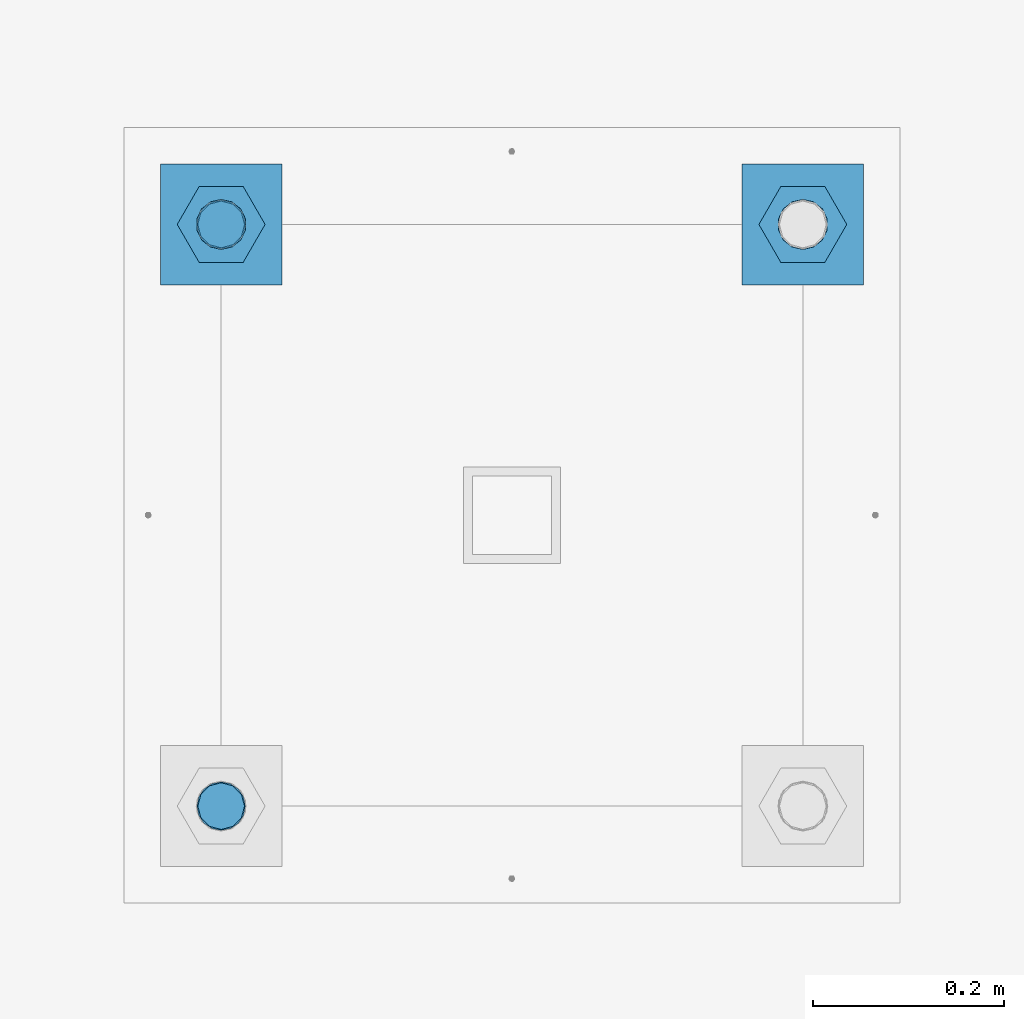
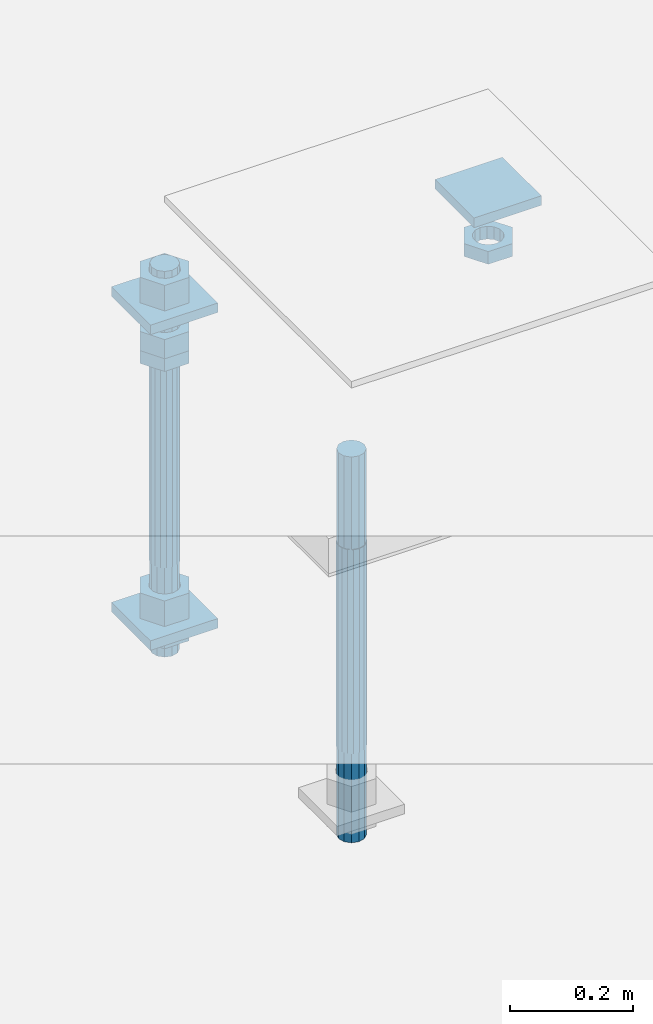
# One storey, part 2749 of 3843: 11 beams, 1 element without a shape of its own.
"""IFC2X3 building model written with IfcOpenShell, lengths in millimetres."""

from ifc_helpers import new_model, si_unit, frame, origin_with_axes, place, context, subcontext, project, spatial, faceted_brep, material, type_object, element, aggregate, save


model = new_model("IFC2X3")

# Units and contexts
model_context = context("Model", 3, precision=1e-05, world=origin_with_axes())
body_context = subcontext(model_context, "Body", "Model", "MODEL_VIEW")
ifc_project = project(units=[si_unit("LENGTHUNIT", "METRE", prefix="MILLI"), si_unit("AREAUNIT", "SQUARE_METRE"), si_unit("VOLUMEUNIT", "CUBIC_METRE"), si_unit("MASSUNIT", "GRAM", prefix="KILO"), si_unit("TIMEUNIT", "SECOND"), si_unit("PLANEANGLEUNIT", "RADIAN"), si_unit("SOLIDANGLEUNIT", "STERADIAN"), si_unit("THERMODYNAMICTEMPERATUREUNIT", "DEGREE_CELSIUS"), si_unit("LUMINOUSINTENSITYUNIT", "LUMEN")], contexts=[model_context])

# Site, building, storey
site_placement = place(None, origin_with_axes())
site = spatial("IfcSite", under=ifc_project, at=site_placement, CompositionType="ELEMENT")
building_placement = place(site_placement, origin_with_axes())
building = spatial("IfcBuilding", under=site, at=building_placement, Name="Undefined", CompositionType="ELEMENT")
storey_placement = place(building_placement, origin_with_axes())
storey = spatial("IfcBuildingStorey", under=building, at=storey_placement, Name="Undefined", CompositionType="ELEMENT", Elevation=0.0)

# Assembly, beams
assembly_placement = place(storey_placement, origin_with_axes())
assembly = element("IfcElementAssembly", 1, at=assembly_placement, inside=storey, Name="TEMPLATE", AssemblyPlace="NOTDEFINED", PredefinedType="RIGID_FRAME")
ifc_material_1 = material(Name="STEEL/A36")
beam_type_1 = type_object("IfcBeamType", PredefinedType="NOTDEFINED")
beam_1_placement = place(assembly_placement, frame((111734.6, 45808.9000015259, 29873.575), z_axis=(1.0, 0.0, 0.0), x_axis=(0.0, 1.0, 0.0)))
beam_1 = element("IfcBeam", 2, at=beam_1_placement, type_object=beam_type_1, material=ifc_material_1, Name="WASHER_PLATE", context=body_context, shape_type="Brep", body=[
    faceted_brep([(0.0, 9.52500000000146, -63.5), (0.0, 9.52500000000146, 63.5), (127.0, 9.52500000000146, 63.5), (127.0, 9.52500000000146, -63.5), (0.0, -9.52500000000146, 63.5), (127.0, -9.52500000000146, 63.5), (0.0, -9.52500000000146, -63.5), (127.0, -9.52500000000146, -63.5)], [[[0, 1, 2, 3]], [[1, 4, 5, 2]], [[4, 6, 7, 5]], [[6, 0, 3, 7]], [[5, 7, 3, 2]], [[6, 4, 1, 0]]]),
])
beam_2_placement = place(assembly_placement, frame((112344.2, 45808.9000015259, 29873.575), z_axis=(1.0, 0.0, 0.0), x_axis=(0.0, 1.0, 0.0)))
beam_2 = element("IfcBeam", 3, at=beam_2_placement, type_object=beam_type_1, material=ifc_material_1, Name="WASHER_PLATE", context=body_context, shape_type="Brep", body=[
    faceted_brep([(0.0, 9.52500000000146, -63.5), (0.0, 9.52500000000146, 63.5), (127.0, 9.52500000000146, 63.5), (127.0, 9.52500000000146, -63.5), (0.0, -9.52500000000146, 63.5), (127.0, -9.52500000000146, 63.5), (0.0, -9.52500000000146, -63.5), (127.0, -9.52500000000146, -63.5)], [[[0, 1, 2, 3]], [[1, 4, 5, 2]], [[4, 6, 7, 5]], [[6, 0, 3, 7]], [[5, 7, 3, 2]], [[6, 4, 1, 0]]]),
])
beam_3_placement = place(assembly_placement, frame((111734.6, 45808.9000015259, 29244.925), z_axis=(1.0, 0.0, 0.0), x_axis=(0.0, 1.0, 0.0)))
beam_3 = element("IfcBeam", 4, at=beam_3_placement, type_object=beam_type_1, material=ifc_material_1, Name="WASHER_PLATE", context=body_context, shape_type="Brep", body=[
    faceted_brep([(0.0, 9.52500000000146, -63.5), (0.0, 9.52500000000146, 63.5), (127.0, 9.52500000000146, 63.5), (127.0, 9.52500000000146, -63.5), (0.0, -9.52500000000146, 63.5), (127.0, -9.52500000000146, 63.5), (0.0, -9.52500000000146, -63.5), (127.0, -9.52500000000146, -63.5)], [[[0, 1, 2, 3]], [[1, 4, 5, 2]], [[4, 6, 7, 5]], [[6, 0, 3, 7]], [[5, 7, 3, 2]], [[6, 4, 1, 0]]]),
])
beam_type_2 = type_object("IfcBeamType", Name="2_HALF_NUT", PredefinedType="NOTDEFINED")
beam_4_placement = place(assembly_placement, frame((111734.6, 45872.4000015259, 29787.85), z_axis=(0.0, 1.0, 0.0), x_axis=(0.0, 0.0, -1.0)))
beam_4 = element("IfcBeam", 5, at=beam_4_placement, type_object=beam_type_2, material=ifc_material_1, Name="NUT", ObjectType="2_HALF_NUT", context=body_context, shape_type="Brep", body=[
    faceted_brep([(0.0, -46.0369987487793, 0.0), (0.0, -23.0184993743896, -39.869213104248), (25.4000000000015, -23.0184993743896, -39.869213104248), (25.4000000000015, -46.0369987487793, 0.0), (0.0, 23.0184993743896, -39.869213104248), (25.4000000000015, 23.0184993743896, -39.869213104248), (0.0, 46.0369987487793, 0.0), (25.4000000000015, 46.0369987487793, 0.0), (0.0, 23.0184993743896, 39.869213104248), (25.4000000000015, 23.0184993743896, 39.869213104248), (0.0, -23.0184993743896, 39.869213104248), (25.4000000000015, -23.0184993743896, 39.869213104248), (0.0, 0.0, 26.1940002441406), (0.0, 11.3650617044477, 23.5999013092805), (25.4000000000015, 11.3650617044477, 23.5999013092805), (25.4000000000015, 0.0, 26.1940002441406), (0.0, 20.4791109456419, 16.3316083006721), (25.4000000000015, 20.4791109456419, 16.3316083006721), (0.0, 25.5370200498292, 5.82867859874386), (25.4000000000015, 25.5370200498292, 5.82867859874386), (0.0, 25.5370200498292, -5.82867859874386), (25.4000000000015, 25.5370200498292, -5.82867859874386), (0.0, 20.4791109456419, -16.3316083006721), (25.4000000000015, 20.4791109456419, -16.3316083006721), (0.0, 11.3650617044477, -23.5999013092805), (25.4000000000015, 11.3650617044477, -23.5999013092805), (0.0, 0.0, -26.1940002441406), (25.4000000000015, 0.0, -26.1940002441406), (0.0, -11.3650617044477, -23.5999013092805), (25.4000000000015, -11.3650617044477, -23.5999013092805), (0.0, -20.4791109456419, -16.3316083006721), (25.4000000000015, -20.4791109456419, -16.3316083006721), (0.0, -25.5370200498292, -5.82867859874386), (25.4000000000015, -25.5370200498292, -5.82867859874386), (0.0, -25.5370200498292, 5.82867859874386), (25.4000000000015, -25.5370200498292, 5.82867859874386), (0.0, -20.4791109456419, 16.3316083006721), (25.4000000000015, -20.4791109456419, 16.3316083006721), (0.0, -11.3650617044477, 23.5999013092805), (25.4000000000015, -11.3650617044477, 23.5999013092805)], [[[0, 1, 2, 3]], [[1, 4, 5, 2]], [[4, 6, 7, 5]], [[6, 8, 9, 7]], [[8, 10, 11, 9]], [[10, 0, 3, 11]], [[12, 13, 14, 15]], [[13, 16, 17, 14]], [[16, 18, 19, 17]], [[18, 20, 21, 19]], [[20, 22, 23, 21]], [[22, 24, 25, 23]], [[24, 26, 27, 25]], [[26, 28, 29, 27]], [[28, 30, 31, 29]], [[30, 32, 33, 31]], [[32, 34, 35, 33]], [[34, 36, 37, 35]], [[36, 38, 39, 37]], [[38, 12, 15, 39]], [[5, 7, 9, 11, 3, 2], [17, 19, 21, 23, 25, 27, 29, 31, 33, 35, 37, 39, 15, 14]], [[10, 8, 6, 4, 1, 0], [38, 36, 34, 32, 30, 28, 26, 24, 22, 20, 18, 16, 13, 12]]]),
])
beam_5_placement = place(assembly_placement, frame((112344.2, 45872.4000015259, 29787.85), z_axis=(0.0, 1.0, 0.0), x_axis=(0.0, 0.0, -1.0)))
beam_5 = element("IfcBeam", 6, at=beam_5_placement, type_object=beam_type_2, material=ifc_material_1, Name="NUT", ObjectType="2_HALF_NUT", context=body_context, shape_type="Brep", body=[
    faceted_brep([(0.0, -46.0369987487793, 0.0), (0.0, -23.0184993743896, -39.869213104248), (25.4000000000015, -23.0184993743896, -39.869213104248), (25.4000000000015, -46.0369987487793, 0.0), (0.0, 23.0184993743896, -39.869213104248), (25.4000000000015, 23.0184993743896, -39.869213104248), (0.0, 46.0369987487793, 0.0), (25.4000000000015, 46.0369987487793, 0.0), (0.0, 23.0184993743896, 39.869213104248), (25.4000000000015, 23.0184993743896, 39.869213104248), (0.0, -23.0184993743896, 39.869213104248), (25.4000000000015, -23.0184993743896, 39.869213104248), (0.0, 0.0, 26.1940002441406), (0.0, 11.3650617044477, 23.5999013092805), (25.4000000000015, 11.3650617044477, 23.5999013092805), (25.4000000000015, 0.0, 26.1940002441406), (0.0, 20.4791109456419, 16.3316083006721), (25.4000000000015, 20.4791109456419, 16.3316083006721), (0.0, 25.5370200498292, 5.82867859874386), (25.4000000000015, 25.5370200498292, 5.82867859874386), (0.0, 25.5370200498292, -5.82867859874386), (25.4000000000015, 25.5370200498292, -5.82867859874386), (0.0, 20.4791109456419, -16.3316083006721), (25.4000000000015, 20.4791109456419, -16.3316083006721), (0.0, 11.3650617044477, -23.5999013092805), (25.4000000000015, 11.3650617044477, -23.5999013092805), (0.0, 0.0, -26.1940002441406), (25.4000000000015, 0.0, -26.1940002441406), (0.0, -11.3650617044477, -23.5999013092805), (25.4000000000015, -11.3650617044477, -23.5999013092805), (0.0, -20.4791109456419, -16.3316083006721), (25.4000000000015, -20.4791109456419, -16.3316083006721), (0.0, -25.5370200498292, -5.82867859874386), (25.4000000000015, -25.5370200498292, -5.82867859874386), (0.0, -25.5370200498292, 5.82867859874386), (25.4000000000015, -25.5370200498292, 5.82867859874386), (0.0, -20.4791109456419, 16.3316083006721), (25.4000000000015, -20.4791109456419, 16.3316083006721), (0.0, -11.3650617044477, 23.5999013092805), (25.4000000000015, -11.3650617044477, 23.5999013092805)], [[[0, 1, 2, 3]], [[1, 4, 5, 2]], [[4, 6, 7, 5]], [[6, 8, 9, 7]], [[8, 10, 11, 9]], [[10, 0, 3, 11]], [[12, 13, 14, 15]], [[13, 16, 17, 14]], [[16, 18, 19, 17]], [[18, 20, 21, 19]], [[20, 22, 23, 21]], [[22, 24, 25, 23]], [[24, 26, 27, 25]], [[26, 28, 29, 27]], [[28, 30, 31, 29]], [[30, 32, 33, 31]], [[32, 34, 35, 33]], [[34, 36, 37, 35]], [[36, 38, 39, 37]], [[38, 12, 15, 39]], [[5, 7, 9, 11, 3, 2], [17, 19, 21, 23, 25, 27, 29, 31, 33, 35, 37, 39, 15, 14]], [[10, 8, 6, 4, 1, 0], [38, 36, 34, 32, 30, 28, 26, 24, 22, 20, 18, 16, 13, 12]]]),
])
beam_6_placement = place(assembly_placement, frame((111734.6, 45872.4000015259, 29235.4), z_axis=(0.0, 1.0, 0.0), x_axis=(0.0, 0.0, -1.0)))
beam_6 = element("IfcBeam", 7, at=beam_6_placement, type_object=beam_type_2, material=ifc_material_1, Name="NUT", ObjectType="2_HALF_NUT", context=body_context, shape_type="Brep", body=[
    faceted_brep([(0.0, -46.0369987487793, 0.0), (0.0, -23.0184993743896, -39.869213104248), (25.4000000000015, -23.0184993743896, -39.869213104248), (25.4000000000015, -46.0369987487793, 0.0), (0.0, 23.0184993743896, -39.869213104248), (25.4000000000015, 23.0184993743896, -39.869213104248), (0.0, 46.0369987487793, 0.0), (25.4000000000015, 46.0369987487793, 0.0), (0.0, 23.0184993743896, 39.869213104248), (25.4000000000015, 23.0184993743896, 39.869213104248), (0.0, -23.0184993743896, 39.869213104248), (25.4000000000015, -23.0184993743896, 39.869213104248), (0.0, 0.0, 26.1940002441406), (0.0, 11.3650617044477, 23.5999013092805), (25.4000000000015, 11.3650617044477, 23.5999013092805), (25.4000000000015, 0.0, 26.1940002441406), (0.0, 20.4791109456419, 16.3316083006721), (25.4000000000015, 20.4791109456419, 16.3316083006721), (0.0, 25.5370200498292, 5.82867859874386), (25.4000000000015, 25.5370200498292, 5.82867859874386), (0.0, 25.5370200498292, -5.82867859874386), (25.4000000000015, 25.5370200498292, -5.82867859874386), (0.0, 20.4791109456419, -16.3316083006721), (25.4000000000015, 20.4791109456419, -16.3316083006721), (0.0, 11.3650617044477, -23.5999013092805), (25.4000000000015, 11.3650617044477, -23.5999013092805), (0.0, 0.0, -26.1940002441406), (25.4000000000015, 0.0, -26.1940002441406), (0.0, -11.3650617044477, -23.5999013092805), (25.4000000000015, -11.3650617044477, -23.5999013092805), (0.0, -20.4791109456419, -16.3316083006721), (25.4000000000015, -20.4791109456419, -16.3316083006721), (0.0, -25.5370200498292, -5.82867859874386), (25.4000000000015, -25.5370200498292, -5.82867859874386), (0.0, -25.5370200498292, 5.82867859874386), (25.4000000000015, -25.5370200498292, 5.82867859874386), (0.0, -20.4791109456419, 16.3316083006721), (25.4000000000015, -20.4791109456419, 16.3316083006721), (0.0, -11.3650617044477, 23.5999013092805), (25.4000000000015, -11.3650617044477, 23.5999013092805)], [[[0, 1, 2, 3]], [[1, 4, 5, 2]], [[4, 6, 7, 5]], [[6, 8, 9, 7]], [[8, 10, 11, 9]], [[10, 0, 3, 11]], [[12, 13, 14, 15]], [[13, 16, 17, 14]], [[16, 18, 19, 17]], [[18, 20, 21, 19]], [[20, 22, 23, 21]], [[22, 24, 25, 23]], [[24, 26, 27, 25]], [[26, 28, 29, 27]], [[28, 30, 31, 29]], [[30, 32, 33, 31]], [[32, 34, 35, 33]], [[34, 36, 37, 35]], [[36, 38, 39, 37]], [[38, 12, 15, 39]], [[5, 7, 9, 11, 3, 2], [17, 19, 21, 23, 25, 27, 29, 31, 33, 35, 37, 39, 15, 14]], [[10, 8, 6, 4, 1, 0], [38, 36, 34, 32, 30, 28, 26, 24, 22, 20, 18, 16, 13, 12]]]),
])
beam_type_3 = type_object("IfcBeamType", Name="2_HEAVY_HEX_NUT", PredefinedType="NOTDEFINED")
beam_7_placement = place(assembly_placement, frame((111734.6, 45872.4000015259, 29825.95), z_axis=(0.0, 1.0, 0.0), x_axis=(0.0, 0.0, -1.0)))
beam_7 = element("IfcBeam", 8, at=beam_7_placement, type_object=beam_type_3, material=ifc_material_1, Name="NUT", ObjectType="2_HEAVY_HEX_NUT", context=body_context, shape_type="Brep", body=[
    faceted_brep([(0.0, -46.0369987487793, 0.0), (0.0, -23.0184993743896, -39.869213104248), (38.0999999999985, -23.0184993743896, -39.869213104248), (38.0999999999985, -46.0369987487793, 0.0), (0.0, 23.0184993743896, -39.869213104248), (38.0999999999985, 23.0184993743896, -39.869213104248), (0.0, 46.0369987487793, 0.0), (38.0999999999985, 46.0369987487793, 0.0), (0.0, 23.0184993743896, 39.869213104248), (38.0999999999985, 23.0184993743896, 39.869213104248), (0.0, -23.0184993743896, 39.869213104248), (38.0999999999985, -23.0184993743896, 39.869213104248), (0.0, 0.0, 26.1940002441406), (0.0, 11.3650617044477, 23.5999013092805), (38.0999999999985, 11.3650617044477, 23.5999013092805), (38.0999999999985, 0.0, 26.1940002441406), (0.0, 20.4791109456419, 16.3316083006721), (38.0999999999985, 20.4791109456419, 16.3316083006721), (0.0, 25.5370200498292, 5.82867859874386), (38.0999999999985, 25.5370200498292, 5.82867859874386), (0.0, 25.5370200498292, -5.82867859874386), (38.0999999999985, 25.5370200498292, -5.82867859874386), (0.0, 20.4791109456419, -16.3316083006721), (38.0999999999985, 20.4791109456419, -16.3316083006721), (0.0, 11.3650617044477, -23.5999013092805), (38.0999999999985, 11.3650617044477, -23.5999013092805), (0.0, 0.0, -26.1940002441406), (38.0999999999985, 0.0, -26.1940002441406), (0.0, -11.3650617044477, -23.5999013092805), (38.0999999999985, -11.3650617044477, -23.5999013092805), (0.0, -20.4791109456419, -16.3316083006721), (38.0999999999985, -20.4791109456419, -16.3316083006721), (0.0, -25.5370200498292, -5.82867859874386), (38.0999999999985, -25.5370200498292, -5.82867859874386), (0.0, -25.5370200498292, 5.82867859874386), (38.0999999999985, -25.5370200498292, 5.82867859874386), (0.0, -20.4791109456419, 16.3316083006721), (38.0999999999985, -20.4791109456419, 16.3316083006721), (0.0, -11.3650617044477, 23.5999013092805), (38.0999999999985, -11.3650617044477, 23.5999013092805)], [[[0, 1, 2, 3]], [[1, 4, 5, 2]], [[4, 6, 7, 5]], [[6, 8, 9, 7]], [[8, 10, 11, 9]], [[10, 0, 3, 11]], [[12, 13, 14, 15]], [[13, 16, 17, 14]], [[16, 18, 19, 17]], [[18, 20, 21, 19]], [[20, 22, 23, 21]], [[22, 24, 25, 23]], [[24, 26, 27, 25]], [[26, 28, 29, 27]], [[28, 30, 31, 29]], [[30, 32, 33, 31]], [[32, 34, 35, 33]], [[34, 36, 37, 35]], [[36, 38, 39, 37]], [[38, 12, 15, 39]], [[5, 7, 9, 11, 3, 2], [17, 19, 21, 23, 25, 27, 29, 31, 33, 35, 37, 39, 15, 14]], [[10, 8, 6, 4, 1, 0], [38, 36, 34, 32, 30, 28, 26, 24, 22, 20, 18, 16, 13, 12]]]),
])
beam_8_placement = place(assembly_placement, frame((111734.6, 45872.4000015259, 29933.9), z_axis=(0.0, 1.0, 0.0), x_axis=(0.0, 0.0, -1.0)))
beam_8 = element("IfcBeam", 9, at=beam_8_placement, type_object=beam_type_3, material=ifc_material_1, Name="NUT", ObjectType="2_HEAVY_HEX_NUT", context=body_context, shape_type="Brep", body=[
    faceted_brep([(0.0, -46.0369987487793, 0.0), (0.0, -23.0184993743896, -39.869213104248), (50.7999999999993, -23.0184993743896, -39.869213104248), (50.7999999999993, -46.0369987487793, 0.0), (0.0, 23.0184993743896, -39.869213104248), (50.7999999999993, 23.0184993743896, -39.869213104248), (0.0, 46.0369987487793, 0.0), (50.7999999999993, 46.0369987487793, 0.0), (0.0, 23.0184993743896, 39.869213104248), (50.7999999999993, 23.0184993743896, 39.869213104248), (0.0, -23.0184993743896, 39.869213104248), (50.7999999999993, -23.0184993743896, 39.869213104248), (0.0, 0.0, 26.1940002441406), (0.0, 11.3650617044477, 23.5999013092805), (50.7999999999993, 11.3650617044477, 23.5999013092805), (50.7999999999993, 0.0, 26.1940002441406), (0.0, 20.4791109456419, 16.3316083006721), (50.7999999999993, 20.4791109456419, 16.3316083006721), (0.0, 25.5370200498292, 5.82867859874386), (50.7999999999993, 25.5370200498292, 5.82867859874386), (0.0, 25.5370200498292, -5.82867859874386), (50.7999999999993, 25.5370200498292, -5.82867859874386), (0.0, 20.4791109456419, -16.3316083006721), (50.7999999999993, 20.4791109456419, -16.3316083006721), (0.0, 11.3650617044477, -23.5999013092805), (50.7999999999993, 11.3650617044477, -23.5999013092805), (0.0, 0.0, -26.1940002441406), (50.7999999999993, 0.0, -26.1940002441406), (0.0, -11.3650617044477, -23.5999013092805), (50.7999999999993, -11.3650617044477, -23.5999013092805), (0.0, -20.4791109456419, -16.3316083006721), (50.7999999999993, -20.4791109456419, -16.3316083006721), (0.0, -25.5370200498292, -5.82867859874386), (50.7999999999993, -25.5370200498292, -5.82867859874386), (0.0, -25.5370200498292, 5.82867859874386), (50.7999999999993, -25.5370200498292, 5.82867859874386), (0.0, -20.4791109456419, 16.3316083006721), (50.7999999999993, -20.4791109456419, 16.3316083006721), (0.0, -11.3650617044477, 23.5999013092805), (50.7999999999993, -11.3650617044477, 23.5999013092805)], [[[0, 1, 2, 3]], [[1, 4, 5, 2]], [[4, 6, 7, 5]], [[6, 8, 9, 7]], [[8, 10, 11, 9]], [[10, 0, 3, 11]], [[12, 13, 14, 15]], [[13, 16, 17, 14]], [[16, 18, 19, 17]], [[18, 20, 21, 19]], [[20, 22, 23, 21]], [[22, 24, 25, 23]], [[24, 26, 27, 25]], [[26, 28, 29, 27]], [[28, 30, 31, 29]], [[30, 32, 33, 31]], [[32, 34, 35, 33]], [[34, 36, 37, 35]], [[36, 38, 39, 37]], [[38, 12, 15, 39]], [[5, 7, 9, 11, 3, 2], [17, 19, 21, 23, 25, 27, 29, 31, 33, 35, 37, 39, 15, 14]], [[10, 8, 6, 4, 1, 0], [38, 36, 34, 32, 30, 28, 26, 24, 22, 20, 18, 16, 13, 12]]]),
])
beam_9_placement = place(assembly_placement, frame((111734.6, 45872.4000015259, 29305.25), z_axis=(0.0, 1.0, 0.0), x_axis=(0.0, 0.0, -1.0)))
beam_9 = element("IfcBeam", 10, at=beam_9_placement, type_object=beam_type_3, material=ifc_material_1, Name="NUT", ObjectType="2_HEAVY_HEX_NUT", context=body_context, shape_type="Brep", body=[
    faceted_brep([(0.0, -46.0369987487793, 0.0), (0.0, -23.0184993743896, -39.869213104248), (50.7999999999993, -23.0184993743896, -39.869213104248), (50.7999999999993, -46.0369987487793, 0.0), (0.0, 23.0184993743896, -39.869213104248), (50.7999999999993, 23.0184993743896, -39.869213104248), (0.0, 46.0369987487793, 0.0), (50.7999999999993, 46.0369987487793, 0.0), (0.0, 23.0184993743896, 39.869213104248), (50.7999999999993, 23.0184993743896, 39.869213104248), (0.0, -23.0184993743896, 39.869213104248), (50.7999999999993, -23.0184993743896, 39.869213104248), (0.0, 0.0, 26.1940002441406), (0.0, 11.3650617044477, 23.5999013092805), (50.7999999999993, 11.3650617044477, 23.5999013092805), (50.7999999999993, 0.0, 26.1940002441406), (0.0, 20.4791109456419, 16.3316083006721), (50.7999999999993, 20.4791109456419, 16.3316083006721), (0.0, 25.5370200498292, 5.82867859874386), (50.7999999999993, 25.5370200498292, 5.82867859874386), (0.0, 25.5370200498292, -5.82867859874386), (50.7999999999993, 25.5370200498292, -5.82867859874386), (0.0, 20.4791109456419, -16.3316083006721), (50.7999999999993, 20.4791109456419, -16.3316083006721), (0.0, 11.3650617044477, -23.5999013092805), (50.7999999999993, 11.3650617044477, -23.5999013092805), (0.0, 0.0, -26.1940002441406), (50.7999999999993, 0.0, -26.1940002441406), (0.0, -11.3650617044477, -23.5999013092805), (50.7999999999993, -11.3650617044477, -23.5999013092805), (0.0, -20.4791109456419, -16.3316083006721), (50.7999999999993, -20.4791109456419, -16.3316083006721), (0.0, -25.5370200498292, -5.82867859874386), (50.7999999999993, -25.5370200498292, -5.82867859874386), (0.0, -25.5370200498292, 5.82867859874386), (50.7999999999993, -25.5370200498292, 5.82867859874386), (0.0, -20.4791109456419, 16.3316083006721), (50.7999999999993, -20.4791109456419, 16.3316083006721), (0.0, -11.3650617044477, 23.5999013092805), (50.7999999999993, -11.3650617044477, 23.5999013092805)], [[[0, 1, 2, 3]], [[1, 4, 5, 2]], [[4, 6, 7, 5]], [[6, 8, 9, 7]], [[8, 10, 11, 9]], [[10, 0, 3, 11]], [[12, 13, 14, 15]], [[13, 16, 17, 14]], [[16, 18, 19, 17]], [[18, 20, 21, 19]], [[20, 22, 23, 21]], [[22, 24, 25, 23]], [[24, 26, 27, 25]], [[26, 28, 29, 27]], [[28, 30, 31, 29]], [[30, 32, 33, 31]], [[32, 34, 35, 33]], [[34, 36, 37, 35]], [[36, 38, 39, 37]], [[38, 12, 15, 39]], [[5, 7, 9, 11, 3, 2], [17, 19, 21, 23, 25, 27, 29, 31, 33, 35, 37, 39, 15, 14]], [[10, 8, 6, 4, 1, 0], [38, 36, 34, 32, 30, 28, 26, 24, 22, 20, 18, 16, 13, 12]]]),
])
ifc_material_2 = material()
beam_type_4 = type_object("IfcBeamType", PredefinedType="NOTDEFINED")
beam_10_placement = place(assembly_placement, frame((111734.6, 45872.4000015259, 29762.45), z_axis=(0.0, 1.0, 0.0), x_axis=(0.0, 0.0, -1.0)))
beam_10 = element("IfcBeam", 11, at=beam_10_placement, type_object=beam_type_4, material=ifc_material_2, Name="ANCHOR_ROD", context=body_context, shape_type="Brep", body=[
    faceted_brep([(-184.150000000001, -21.217622392709, 12.25), (-184.150000000001, -12.2499999999854, 21.2176223927163), (-184.150000000001, 1.45519152283669e-11, 24.5), (-184.150000000001, 12.2500000000146, 21.2176223927163), (-184.150000000001, 21.2176223927381, 12.25), (-184.150000000001, 24.5000000000146, 0.0), (-184.150000000001, 21.2176223927381, -12.25), (-184.150000000001, 12.2500000000146, -21.2176223927163), (-184.150000000001, 1.45519152283669e-11, -24.5), (-184.150000000001, -12.2499999999854, -21.2176223927163), (-184.150000000001, -21.217622392709, -12.25), (-184.150000000001, -24.4999999999854, 0.0), (0.0, 24.5000000000146, 0.0), (0.0, 21.2176223927381, -12.25), (0.0, 12.2500000000146, -21.2176223927163), (0.0, 1.45519152283669e-11, -24.5), (0.0, -12.2499999999854, -21.2176223927163), (0.0, -21.217622392709, -12.25), (0.0, -24.4999999999854, 0.0), (0.0, -21.217622392709, 12.25), (0.0, -12.2499999999854, 21.2176223927163), (0.0, 1.45519152283669e-11, 24.5), (0.0, 12.2500000000146, 21.2176223927163), (0.0, 21.2176223927381, 12.25), (0.0, -23.4665401257807, 9.72015918207035), (0.0, -17.9605122421344, 17.9605122421417), (0.0, -9.72015918207762, 23.466540125788), (0.0, 0.0, 25.4000000000015), (0.0, 9.72015918207762, 23.466540125788), (0.0, 17.9605122421344, 17.9605122421417), (0.0, 23.4665401257807, 9.72015918207035), (0.0, 25.3999996185303, 0.0), (0.0, 23.4665401257807, -9.72015918207035), (0.0, 17.9605122421344, -17.9605122421417), (0.0, 9.72015918207762, -23.466540125788), (0.0, 0.0, -25.4000000000015), (0.0, -9.72015918207762, -23.466540125788), (0.0, -17.9605122421344, -17.9605122421417), (0.0, -23.4665401257807, -9.72015918207035), (0.0, -25.3999996185303, 0.0), (406.399999999998, -25.3999999999942, 0.0), (406.399999999998, -23.4665401257807, 9.72015918207035), (406.399999999998, -17.9605122421344, 17.9605122421417), (406.399999999998, -9.72015918207762, 23.466540125788), (406.399999999998, 0.0, 25.4000000000015), (406.399999999998, 9.72015918207762, 23.466540125788), (406.399999999998, 17.9605122421344, 17.9605122421417), (406.399999999998, 23.4665401257807, 9.72015918207035), (406.399999999998, 25.3999999999942, 0.0), (406.399999999998, 23.4665401257807, -9.72015918207035), (406.399999999998, 17.9605122421344, -17.9605122421417), (406.399999999998, 9.72015918207762, -23.466540125788), (406.399999999998, 0.0, -25.4000000000015), (406.399999999998, -9.72015918207762, -23.466540125788), (406.399999999998, -17.9605122421344, -17.9605122421417), (406.399999999998, -23.4665401257807, -9.72015918207035), (406.399999999998, -12.2499999999854, 21.2176223927163), (406.399999999998, 1.45519152283669e-11, 24.5), (406.399999999998, 12.2500000000146, 21.2176223927163), (406.399999999998, 21.2176223927381, 12.25), (406.399999999998, 24.5000000000146, 0.0), (406.399999999998, 21.2176223927381, -12.25), (406.399999999998, 12.2500000000146, -21.2176223927163), (406.399999999998, 1.45519152283669e-11, -24.5), (406.399999999998, -12.2499999999854, -21.2176223927163), (406.399999999998, -21.217622392709, -12.25), (406.399999999998, -24.4999999999854, 0.0), (406.399999999998, -21.217622392709, 12.25), (584.200000000001, -12.2499999999854, -21.2176223927163), (584.200000000001, 1.45519152283669e-11, -24.5), (584.200000000001, 12.2500000000146, -21.2176223927163), (584.200000000001, 21.2176223927381, -12.25), (584.200000000001, 24.5000000000146, 0.0), (584.200000000001, 21.2176223927381, 12.25), (584.200000000001, 12.2500000000146, 21.2176223927163), (584.200000000001, 1.45519152283669e-11, 24.5), (584.200000000001, -12.2499999999854, 21.2176223927163), (584.200000000001, -21.217622392709, 12.25), (584.200000000001, -24.4999999999854, 0.0), (584.200000000001, -21.217622392709, -12.25)], [[[0, 1, 2, 3, 4, 5, 6, 7, 8, 9, 10, 11]], [[6, 5, 12, 13]], [[7, 6, 13, 14]], [[8, 7, 14, 15]], [[9, 8, 15, 16]], [[10, 9, 16, 17]], [[11, 10, 17, 18]], [[0, 11, 18, 19]], [[1, 0, 19, 20]], [[2, 1, 20, 21]], [[3, 2, 21, 22]], [[4, 3, 22, 23]], [[5, 4, 23, 12]], [[24, 25, 26, 27, 28, 29, 30, 31, 32, 33, 34, 35, 36, 37, 38, 39], [22, 21, 20, 19, 18, 17, 16, 15, 14, 13, 12, 23]], [[24, 39, 40, 41]], [[25, 24, 41, 42]], [[26, 25, 42, 43]], [[27, 26, 43, 44]], [[28, 27, 44, 45]], [[29, 28, 45, 46]], [[30, 29, 46, 47]], [[31, 30, 47, 48]], [[32, 31, 48, 49]], [[33, 32, 49, 50]], [[34, 33, 50, 51]], [[35, 34, 51, 52]], [[36, 35, 52, 53]], [[37, 36, 53, 54]], [[38, 37, 54, 55]], [[39, 38, 55, 40]], [[54, 53, 52, 51, 50, 49, 48, 47, 46, 45, 44, 43, 42, 41, 40, 55], [56, 57, 58, 59, 60, 61, 62, 63, 64, 65, 66, 67]], [[68, 69, 70, 71, 72, 73, 74, 75, 76, 77, 78, 79]], [[76, 75, 57, 56]], [[77, 76, 56, 67]], [[78, 77, 67, 66]], [[79, 78, 66, 65]], [[68, 79, 65, 64]], [[69, 68, 64, 63]], [[70, 69, 63, 62]], [[71, 70, 62, 61]], [[72, 71, 61, 60]], [[73, 72, 60, 59]], [[74, 73, 59, 58]], [[75, 74, 58, 57]]]),
])
beam_11_placement = place(assembly_placement, frame((111734.6, 45262.8000015259, 29762.45), z_axis=(0.0, 1.0, 0.0), x_axis=(0.0, 0.0, -1.0)))
beam_11 = element("IfcBeam", 12, at=beam_11_placement, type_object=beam_type_4, material=ifc_material_2, Name="ANCHOR_ROD", context=body_context, shape_type="Brep", body=[
    faceted_brep([(-184.150000000001, -21.217622392709, 12.25), (-184.150000000001, -12.2499999999854, 21.2176223927163), (-184.150000000001, 1.45519152283669e-11, 24.5), (-184.150000000001, 12.2500000000146, 21.2176223927163), (-184.150000000001, 21.2176223927381, 12.25), (-184.150000000001, 24.5000000000146, 0.0), (-184.150000000001, 21.2176223927381, -12.25), (-184.150000000001, 12.2500000000146, -21.2176223927163), (-184.150000000001, 1.45519152283669e-11, -24.5), (-184.150000000001, -12.2499999999854, -21.2176223927163), (-184.150000000001, -21.217622392709, -12.25), (-184.150000000001, -24.4999999999854, 0.0), (0.0, 24.5000000000146, 0.0), (0.0, 21.2176223927381, -12.25), (0.0, 12.2500000000146, -21.2176223927163), (0.0, 1.45519152283669e-11, -24.5), (0.0, -12.2499999999854, -21.2176223927163), (0.0, -21.217622392709, -12.25), (0.0, -24.4999999999854, 0.0), (0.0, -21.217622392709, 12.25), (0.0, -12.2499999999854, 21.2176223927163), (0.0, 1.45519152283669e-11, 24.5), (0.0, 12.2500000000146, 21.2176223927163), (0.0, 21.2176223927381, 12.25), (0.0, -23.4665401257807, 9.72015918207035), (0.0, -17.9605122421344, 17.9605122421417), (0.0, -9.72015918207762, 23.466540125788), (0.0, 0.0, 25.4000000000015), (0.0, 9.72015918207762, 23.466540125788), (0.0, 17.9605122421344, 17.9605122421417), (0.0, 23.4665401257807, 9.72015918207035), (0.0, 25.3999996185303, 0.0), (0.0, 23.4665401257807, -9.72015918207035), (0.0, 17.9605122421344, -17.9605122421417), (0.0, 9.72015918207762, -23.466540125788), (0.0, 0.0, -25.4000000000015), (0.0, -9.72015918207762, -23.466540125788), (0.0, -17.9605122421344, -17.9605122421417), (0.0, -23.4665401257807, -9.72015918207035), (0.0, -25.3999996185303, 0.0), (406.399999999998, -25.3999999999942, 0.0), (406.399999999998, -23.4665401257807, 9.72015918207035), (406.399999999998, -17.9605122421344, 17.9605122421417), (406.399999999998, -9.72015918207762, 23.466540125788), (406.399999999998, 0.0, 25.4000000000015), (406.399999999998, 9.72015918207762, 23.466540125788), (406.399999999998, 17.9605122421344, 17.9605122421417), (406.399999999998, 23.4665401257807, 9.72015918207035), (406.399999999998, 25.3999999999942, 0.0), (406.399999999998, 23.4665401257807, -9.72015918207035), (406.399999999998, 17.9605122421344, -17.9605122421417), (406.399999999998, 9.72015918207762, -23.466540125788), (406.399999999998, 0.0, -25.4000000000015), (406.399999999998, -9.72015918207762, -23.466540125788), (406.399999999998, -17.9605122421344, -17.9605122421417), (406.399999999998, -23.4665401257807, -9.72015918207035), (406.399999999998, -12.2499999999854, 21.2176223927163), (406.399999999998, 1.45519152283669e-11, 24.5), (406.399999999998, 12.2500000000146, 21.2176223927163), (406.399999999998, 21.2176223927381, 12.25), (406.399999999998, 24.5000000000146, 0.0), (406.399999999998, 21.2176223927381, -12.25), (406.399999999998, 12.2500000000146, -21.2176223927163), (406.399999999998, 1.45519152283669e-11, -24.5), (406.399999999998, -12.2499999999854, -21.2176223927163), (406.399999999998, -21.217622392709, -12.25), (406.399999999998, -24.4999999999854, 0.0), (406.399999999998, -21.217622392709, 12.25), (584.200000000001, -12.2499999999854, -21.2176223927163), (584.200000000001, 1.45519152283669e-11, -24.5), (584.200000000001, 12.2500000000146, -21.2176223927163), (584.200000000001, 21.2176223927381, -12.25), (584.200000000001, 24.5000000000146, 0.0), (584.200000000001, 21.2176223927381, 12.25), (584.200000000001, 12.2500000000146, 21.2176223927163), (584.200000000001, 1.45519152283669e-11, 24.5), (584.200000000001, -12.2499999999854, 21.2176223927163), (584.200000000001, -21.217622392709, 12.25), (584.200000000001, -24.4999999999854, 0.0), (584.200000000001, -21.217622392709, -12.25)], [[[0, 1, 2, 3, 4, 5, 6, 7, 8, 9, 10, 11]], [[6, 5, 12, 13]], [[7, 6, 13, 14]], [[8, 7, 14, 15]], [[9, 8, 15, 16]], [[10, 9, 16, 17]], [[11, 10, 17, 18]], [[0, 11, 18, 19]], [[1, 0, 19, 20]], [[2, 1, 20, 21]], [[3, 2, 21, 22]], [[4, 3, 22, 23]], [[5, 4, 23, 12]], [[24, 25, 26, 27, 28, 29, 30, 31, 32, 33, 34, 35, 36, 37, 38, 39], [22, 21, 20, 19, 18, 17, 16, 15, 14, 13, 12, 23]], [[24, 39, 40, 41]], [[25, 24, 41, 42]], [[26, 25, 42, 43]], [[27, 26, 43, 44]], [[28, 27, 44, 45]], [[29, 28, 45, 46]], [[30, 29, 46, 47]], [[31, 30, 47, 48]], [[32, 31, 48, 49]], [[33, 32, 49, 50]], [[34, 33, 50, 51]], [[35, 34, 51, 52]], [[36, 35, 52, 53]], [[37, 36, 53, 54]], [[38, 37, 54, 55]], [[39, 38, 55, 40]], [[54, 53, 52, 51, 50, 49, 48, 47, 46, 45, 44, 43, 42, 41, 40, 55], [56, 57, 58, 59, 60, 61, 62, 63, 64, 65, 66, 67]], [[68, 69, 70, 71, 72, 73, 74, 75, 76, 77, 78, 79]], [[76, 75, 57, 56]], [[77, 76, 56, 67]], [[78, 77, 67, 66]], [[79, 78, 66, 65]], [[68, 79, 65, 64]], [[69, 68, 64, 63]], [[70, 69, 63, 62]], [[71, 70, 62, 61]], [[72, 71, 61, 60]], [[73, 72, 60, 59]], [[74, 73, 59, 58]], [[75, 74, 58, 57]]]),
])
aggregate(assembly, [beam_4, beam_5, beam_1, beam_2, beam_10, beam_7, beam_8, beam_9, beam_6, beam_3, beam_11])

save(model, "model.ifc")
